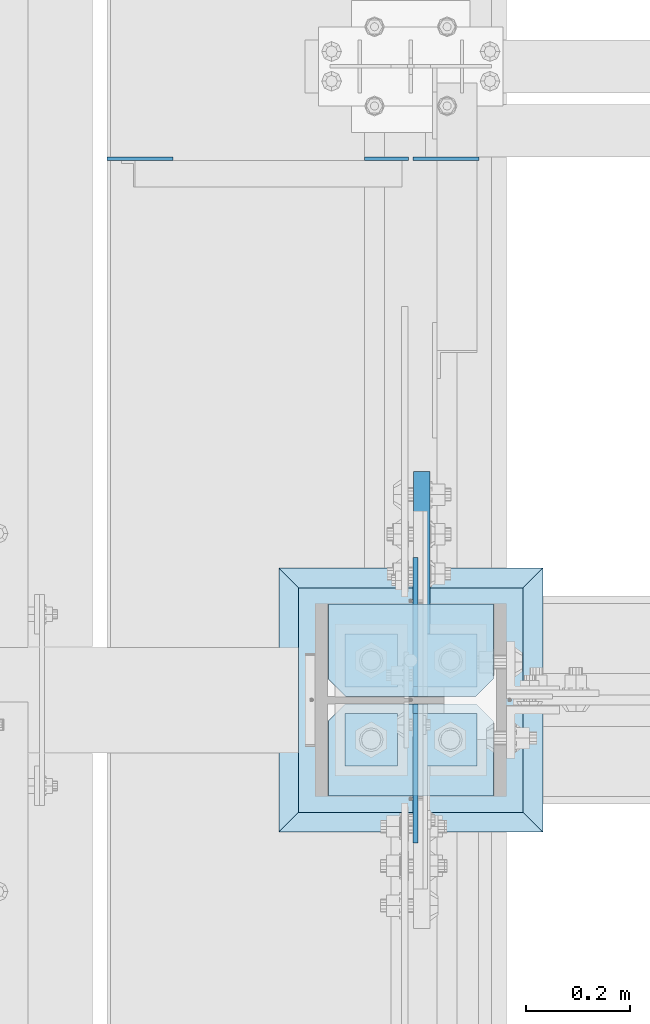
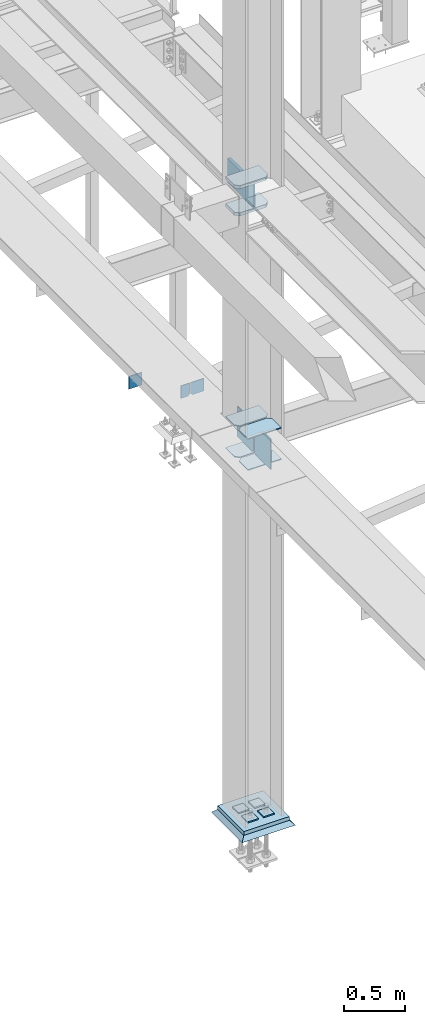
# One storey, part 3391 of 3843: 18 plates, 4 elements without a shape of their own.
"""IFC2X3 building model written with IfcOpenShell, lengths in millimetres."""

from ifc_helpers import new_model, si_unit, frame, origin_with_axes, place, context, subcontext, project, spatial, faceted_brep, material, type_object, element, aggregate, save


model = new_model("IFC2X3")

# Units and contexts
model_context = context("Model", 3, precision=1e-05, world=origin_with_axes())
body_context = subcontext(model_context, "Body", "Model", "MODEL_VIEW")
ifc_project = project(units=[si_unit("LENGTHUNIT", "METRE", prefix="MILLI"), si_unit("AREAUNIT", "SQUARE_METRE"), si_unit("VOLUMEUNIT", "CUBIC_METRE"), si_unit("MASSUNIT", "GRAM", prefix="KILO"), si_unit("TIMEUNIT", "SECOND"), si_unit("PLANEANGLEUNIT", "RADIAN"), si_unit("SOLIDANGLEUNIT", "STERADIAN"), si_unit("THERMODYNAMICTEMPERATUREUNIT", "DEGREE_CELSIUS"), si_unit("LUMINOUSINTENSITYUNIT", "LUMEN")], contexts=[model_context])

# Site, building, storey
site_placement = place(None, origin_with_axes())
site = spatial("IfcSite", under=ifc_project, at=site_placement, CompositionType="ELEMENT")
building_placement = place(site_placement, origin_with_axes())
building = spatial("IfcBuilding", under=site, at=building_placement, Name="Undefined", CompositionType="ELEMENT")
storey_placement = place(building_placement, origin_with_axes())
storey = spatial("IfcBuildingStorey", under=building, at=storey_placement, Name="Undefined", CompositionType="ELEMENT", Elevation=0.0)

# Assembly, plates
assembly_1_placement = place(storey_placement, origin_with_axes())
assembly_1 = element("IfcElementAssembly", 1, at=assembly_1_placement, inside=storey, Name="BEAM", AssemblyPlace="NOTDEFINED", PredefinedType="RIGID_FRAME")
ifc_material_1 = material(Name="STEEL/A572-50")
plate_type_1 = type_object("IfcPlateType", PredefinedType="NOTDEFINED")
plate_1_placement = place(assembly_1_placement, frame((36579.96875, 85026.5, 33769.3), z_axis=(0.0, 0.0, -1.0), x_axis=(1.0, 0.0, 0.0)))
plate_1 = element("IfcPlate", 2, at=plate_1_placement, type_object=plate_type_1, material=ifc_material_1, Name="PLATE", context=body_context, shape_type="Brep", body=[
    faceted_brep([(0.0, -3.17499999999927, 0.0), (0.0, -3.17500000000291, 107.950000000004), (0.0, 3.17500000000291, 107.950000000004), (0.0, 3.17499999999927, 0.0), (19.0500000000029, -3.17500000000291, 127.0), (19.0500000000029, 3.17500000000291, 127.0), (127.0, -3.17500000000291, 127.0), (127.0, 3.17500000000291, 127.0), (127.0, -3.17500000000291, 0.0), (127.0, 3.17500000000291, 0.0)], [[[0, 1, 2, 3]], [[1, 4, 5, 2]], [[4, 6, 7, 5]], [[6, 8, 9, 7]], [[8, 0, 3, 9]], [[5, 7, 9, 3, 2]], [[8, 6, 4, 1, 0]]]),
])
plate_2_placement = place(assembly_1_placement, frame((35991.8000305176, 85026.5000000001, 33909.0000061035), z_axis=(0.0, 0.0, 1.0), x_axis=(1.0, 0.0, 0.0)))
plate_2 = element("IfcPlate", 3, at=plate_2_placement, type_object=plate_type_1, material=ifc_material_1, Name="PLATE", context=body_context, shape_type="Brep", body=[
    faceted_brep([(0.0, -3.17499999999927, 0.0), (-6.10351708019152e-06, -3.17500000000291, 126.999993896483), (-6.10351708019152e-06, 3.17500000000291, 126.999993896483), (0.0, 3.17499999999927, 0.0), (127.0, -3.17500000000291, 127.0), (127.0, 3.17500000000291, 127.0), (127.0, -3.17500000000291, 0.0), (127.0, 3.17500000000291, 0.0)], [[[0, 1, 2, 3]], [[1, 4, 5, 2]], [[4, 6, 7, 5]], [[6, 0, 3, 7]], [[5, 7, 3, 2]], [[6, 4, 1, 0]]]),
])
plate_type_2 = type_object("IfcPlateType", PredefinedType="NOTDEFINED")
plate_3_placement = place(assembly_1_placement, frame((36572.0312591215, 85026.5, 33769.3), z_axis=(0.0, 0.0, -1.0), x_axis=(-1.0, 0.0, 0.0)))
plate_3 = element("IfcPlate", 4, at=plate_3_placement, type_object=plate_type_2, material=ifc_material_1, Name="PLATE", context=body_context, shape_type="Brep", body=[
    faceted_brep([(0.0, -3.17499999999927, 0.0), (0.0, -3.17500000000291, 107.950000000004), (0.0, 3.17500000000291, 107.950000000004), (0.0, 3.17499999999927, 0.0), (19.0500000000029, -3.17500000000291, 127.0), (19.0500000000029, 3.17500000000291, 127.0), (84.9312591264534, -3.17500000000291, 126.999993896701), (84.9312591264534, 3.17500000000291, 126.999993896701), (84.9312500000015, -3.17500000000291, 2.18278728425503e-10), (84.9312500000015, 3.17500000000291, 2.18278728425503e-10)], [[[0, 1, 2, 3]], [[1, 4, 5, 2]], [[4, 6, 7, 5]], [[6, 8, 9, 7]], [[8, 0, 3, 9]], [[5, 7, 9, 3, 2]], [[8, 6, 4, 1, 0]]]),
])
aggregate(assembly_1, [plate_1, plate_3, plate_2])

assembly_2_placement = place(storey_placement, origin_with_axes())
assembly_2 = element("IfcElementAssembly", 5, at=assembly_2_placement, inside=storey, Name="COLUMN", AssemblyPlace="NOTDEFINED", PredefinedType="RIGID_FRAME")
plate_type_3 = type_object("IfcPlateType", PredefinedType="NOTDEFINED")
plate_4_placement = place(assembly_2_placement, frame((36417.25, 83800.15625, 33688.3375), z_axis=(1.0, 0.0, 0.0), x_axis=(0.0, 1.0, 0.0)))
plate_4 = element("IfcPlate", 6, at=plate_4_placement, type_object=plate_type_3, material=ifc_material_1, Name="PLATE", context=body_context, shape_type="Brep", body=[
    faceted_brep([(0.0, -4.76249999999709, 0.0), (0.0, -4.76249999785796, 317.500000005042), (0.0, 4.76250000210712, 317.50000000505), (0.0, 4.76249999999709, 0.0), (144.462501525879, -4.76249999999709, 317.5), (144.462501525879, 4.76249999999709, 317.5), (177.800003051758, -4.76249999999709, 284.162498474121), (177.800003051758, 4.76249999999709, 284.162498474121), (177.800003051758, -4.76249999999709, 33.3375015258789), (177.800003051758, 4.76249999999709, 33.3375015258789), (144.462501525879, -4.76249999999709, 0.0), (144.462501525879, 4.76249999999709, 0.0)], [[[0, 1, 2, 3]], [[1, 4, 5, 2]], [[4, 6, 7, 5]], [[6, 8, 9, 7]], [[8, 10, 11, 9]], [[10, 0, 3, 11]], [[5, 7, 9, 11, 3, 2]], [[10, 8, 6, 4, 1, 0]]]),
])
plate_5_placement = place(assembly_2_placement, frame((36417.25, 83800.15625, 34002.6625), z_axis=(1.0, 0.0, 0.0), x_axis=(0.0, 1.0, 0.0)))
plate_5 = element("IfcPlate", 7, at=plate_5_placement, type_object=plate_type_3, material=ifc_material_1, Name="PLATE", context=body_context, shape_type="Brep", body=[
    faceted_brep([(0.0, -4.76249999999709, 0.0), (0.0, -4.76249999785796, 317.500000005042), (0.0, 4.76250000210712, 317.50000000505), (0.0, 4.76249999999709, 0.0), (144.462501525879, -4.76249999999709, 317.5), (144.462501525879, 4.76249999999709, 317.5), (177.800003051758, -4.76249999999709, 284.162498474121), (177.800003051758, 4.76249999999709, 284.162498474121), (177.800003051758, -4.76249999999709, 33.3375015258789), (177.800003051758, 4.76249999999709, 33.3375015258789), (144.462501525879, -4.76249999999709, 0.0), (144.462501525879, 4.76249999999709, 0.0)], [[[0, 1, 2, 3]], [[1, 4, 5, 2]], [[4, 6, 7, 5]], [[6, 8, 9, 7]], [[8, 10, 11, 9]], [[10, 0, 3, 11]], [[5, 7, 9, 11, 3, 2]], [[10, 8, 6, 4, 1, 0]]]),
])
plate_6_placement = place(assembly_2_placement, frame((36734.75, 84170.04375, 33688.3375), z_axis=(-1.0, 0.0, 0.0), x_axis=(0.0, -1.0, 0.0)))
plate_6 = element("IfcPlate", 8, at=plate_6_placement, type_object=plate_type_3, material=ifc_material_1, Name="PLATE", context=body_context, shape_type="Brep", body=[
    faceted_brep([(0.0, -4.76249999999709, 0.0), (0.0, -4.76249999785796, 317.500000005042), (0.0, 4.76250000210712, 317.50000000505), (0.0, 4.76249999999709, 0.0), (144.462501525879, -4.76249999999709, 317.5), (144.462501525879, 4.76249999999709, 317.5), (177.800003051758, -4.76249999999709, 284.162498474121), (177.800003051758, 4.76249999999709, 284.162498474121), (177.800003051758, -4.76249999999709, 33.3375015258789), (177.800003051758, 4.76249999999709, 33.3375015258789), (144.462501525879, -4.76249999999709, 0.0), (144.462501525879, 4.76249999999709, 0.0)], [[[0, 1, 2, 3]], [[1, 4, 5, 2]], [[4, 6, 7, 5]], [[6, 8, 9, 7]], [[8, 10, 11, 9]], [[10, 0, 3, 11]], [[5, 7, 9, 11, 3, 2]], [[10, 8, 6, 4, 1, 0]]]),
])
plate_7_placement = place(assembly_2_placement, frame((36734.75, 84170.04375, 34002.6625), z_axis=(-1.0, 0.0, 0.0), x_axis=(0.0, -1.0, 0.0)))
plate_7 = element("IfcPlate", 9, at=plate_7_placement, type_object=plate_type_3, material=ifc_material_1, Name="PLATE", context=body_context, shape_type="Brep", body=[
    faceted_brep([(0.0, -4.76249999999709, 0.0), (0.0, -4.76249999785796, 317.500000005042), (0.0, 4.76250000210712, 317.50000000505), (0.0, 4.76249999999709, 0.0), (144.462501525879, -4.76249999999709, 317.5), (144.462501525879, 4.76249999999709, 317.5), (177.800003051758, -4.76249999999709, 284.162498474121), (177.800003051758, 4.76249999999709, 284.162498474121), (177.800003051758, -4.76249999999709, 33.3375015258789), (177.800003051758, 4.76249999999709, 33.3375015258789), (144.462501525879, -4.76249999999709, 0.0), (144.462501525879, 4.76249999999709, 0.0)], [[[0, 1, 2, 3]], [[1, 4, 5, 2]], [[4, 6, 7, 5]], [[6, 8, 9, 7]], [[8, 10, 11, 9]], [[10, 0, 3, 11]], [[5, 7, 9, 11, 3, 2]], [[10, 8, 6, 4, 1, 0]]]),
])
plate_type_4 = type_object("IfcPlateType", PredefinedType="NOTDEFINED")
plate_8_placement = place(assembly_2_placement, frame((36734.75, 84170.04375, 36128.325), z_axis=(-1.0, 0.0, 0.0), x_axis=(0.0, -1.0, 0.0)))
plate_8 = element("IfcPlate", 10, at=plate_8_placement, type_object=plate_type_4, material=ifc_material_1, Name="PLATE", context=body_context, shape_type="Brep", body=[
    faceted_brep([(0.0, -15.875, 0.0), (0.0, -15.875, 317.5), (0.0, 15.875, 317.5), (0.0, 15.875, 0.0), (144.462498511086, -15.874999999156, 317.499999999665), (144.462498511086, 15.875000000844, 317.499999999578), (177.800000033079, -15.8749999992506, 284.162498473786), (177.800000033079, 15.8750000007494, 284.162498473699), (177.800000003888, -15.8749999999054, 33.3375015259226), (177.800000003888, 15.8750000000946, 33.3375015258353), (144.462498474124, -15.875, 0.0), (144.462498474124, 15.875, 0.0)], [[[0, 1, 2, 3]], [[1, 4, 5, 2]], [[4, 6, 7, 5]], [[6, 8, 9, 7]], [[8, 10, 11, 9]], [[10, 0, 3, 11]], [[5, 7, 9, 11, 3, 2]], [[10, 8, 6, 4, 1, 0]]]),
])
plate_9_placement = place(assembly_2_placement, frame((36734.75, 84170.04375, 36401.375), z_axis=(-1.0, 0.0, 0.0), x_axis=(0.0, -1.0, 0.0)))
plate_9 = element("IfcPlate", 11, at=plate_9_placement, type_object=plate_type_4, material=ifc_material_1, Name="PLATE", context=body_context, shape_type="Brep", body=[
    faceted_brep([(0.0, -15.875, 0.0), (0.0, -15.875, 317.5), (0.0, 15.875, 317.5), (0.0, 15.875, 0.0), (144.462498511086, -15.874999999156, 317.499999999665), (144.462498511086, 15.875000000844, 317.499999999578), (177.800000033079, -15.8749999992506, 284.162498473786), (177.800000033079, 15.8750000007494, 284.162498473699), (177.800000003888, -15.8749999999054, 33.3375015259226), (177.800000003888, 15.8750000000946, 33.3375015258353), (144.462498474124, -15.875, 0.0), (144.462498474124, 15.875, 0.0)], [[[0, 1, 2, 3]], [[1, 4, 5, 2]], [[4, 6, 7, 5]], [[6, 8, 9, 7]], [[8, 10, 11, 9]], [[10, 0, 3, 11]], [[5, 7, 9, 11, 3, 2]], [[10, 8, 6, 4, 1, 0]]]),
])

assembly_3_placement = place(storey_placement, origin_with_axes())
assembly_3 = element("IfcElementAssembly", 12, at=assembly_3_placement, inside=storey, Name="TEMPLATE", AssemblyPlace="NOTDEFINED", PredefinedType="RIGID_FRAME")
plate_type_5 = type_object("IfcPlateType", PredefinedType="NOTDEFINED")
plate_10_placement = place(assembly_3_placement, frame((36601.4, 83959.7, 30105.35), z_axis=(0.0, -1.0, 0.0), x_axis=(1.0, 0.0, 0.0)))
plate_10 = element("IfcPlate", 13, at=plate_10_placement, type_object=plate_type_5, material=ifc_material_1, Name="Washer Plate", context=body_context, shape_type="Brep", body=[
    faceted_brep([(0.0, -6.3499999046162, 0.0), (-1.67347025126219e-10, -6.35000000000582, 101.600000000151), (-1.67347025126219e-10, 6.35000000000582, 101.600000000151), (7.27595761418343e-12, 6.3499999046162, 0.0), (101.599998474121, -6.34999999999854, 101.599998474121), (101.599998474121, 6.34999999999854, 101.599998474121), (101.6, -6.34999999999854, 0.0), (101.6, 6.34999999999854, 0.0)], [[[0, 1, 2, 3]], [[1, 4, 5, 2]], [[4, 6, 7, 5]], [[6, 0, 3, 7]], [[5, 7, 3, 2]], [[6, 4, 1, 0]]]),
])
plate_11_placement = place(assembly_3_placement, frame((36601.4, 84112.1, 30105.35), z_axis=(0.0, -1.0, 0.0), x_axis=(1.0, 0.0, 0.0)))
plate_11 = element("IfcPlate", 14, at=plate_11_placement, type_object=plate_type_5, material=ifc_material_1, Name="Washer Plate", context=body_context, shape_type="Brep", body=[
    faceted_brep([(0.0, -6.3499999046162, 0.0), (-1.67347025126219e-10, -6.35000000000582, 101.600000000151), (-1.67347025126219e-10, 6.35000000000582, 101.600000000151), (7.27595761418343e-12, 6.3499999046162, 0.0), (101.599998474121, -6.34999999999854, 101.599998474121), (101.599998474121, 6.34999999999854, 101.599998474121), (101.6, -6.34999999999854, 0.0), (101.6, 6.34999999999854, 0.0)], [[[0, 1, 2, 3]], [[1, 4, 5, 2]], [[4, 6, 7, 5]], [[6, 0, 3, 7]], [[5, 7, 3, 2]], [[6, 4, 1, 0]]]),
])
plate_12_placement = place(assembly_3_placement, frame((36449.0, 83959.7, 30105.35), z_axis=(0.0, -1.0, 0.0), x_axis=(1.0, 0.0, 0.0)))
plate_12 = element("IfcPlate", 15, at=plate_12_placement, type_object=plate_type_5, material=ifc_material_1, Name="Washer Plate", context=body_context, shape_type="Brep", body=[
    faceted_brep([(0.0, -6.3499999046162, 0.0), (-1.67347025126219e-10, -6.35000000000582, 101.600000000151), (-1.67347025126219e-10, 6.35000000000582, 101.600000000151), (7.27595761418343e-12, 6.3499999046162, 0.0), (101.599998474121, -6.34999999999854, 101.599998474121), (101.599998474121, 6.34999999999854, 101.599998474121), (101.6, -6.34999999999854, 0.0), (101.6, 6.34999999999854, 0.0)], [[[0, 1, 2, 3]], [[1, 4, 5, 2]], [[4, 6, 7, 5]], [[6, 0, 3, 7]], [[5, 7, 3, 2]], [[6, 4, 1, 0]]]),
])
plate_13_placement = place(assembly_3_placement, frame((36449.0, 84112.1, 30105.35), z_axis=(0.0, -1.0, 0.0), x_axis=(1.0, 0.0, 0.0)))
plate_13 = element("IfcPlate", 16, at=plate_13_placement, type_object=plate_type_5, material=ifc_material_1, Name="Washer Plate", context=body_context, shape_type="Brep", body=[
    faceted_brep([(0.0, -6.3499999046162, 0.0), (-1.67347025126219e-10, -6.35000000000582, 101.600000000151), (-1.67347025126219e-10, 6.35000000000582, 101.600000000151), (7.27595761418343e-12, 6.3499999046162, 0.0), (101.599998474121, -6.34999999999854, 101.599998474121), (101.599998474121, 6.34999999999854, 101.599998474121), (101.6, -6.34999999999854, 0.0), (101.6, 6.34999999999854, 0.0)], [[[0, 1, 2, 3]], [[1, 4, 5, 2]], [[4, 6, 7, 5]], [[6, 0, 3, 7]], [[5, 7, 3, 2]], [[6, 4, 1, 0]]]),
])
aggregate(assembly_3, [plate_10, plate_11, plate_12, plate_13])

# Plate
plate_type_6 = type_object("IfcPlateType", PredefinedType="NOTDEFINED")
plate_14_placement = place(assembly_2_placement, frame((36584.73125, 83977.95625, 33712.1500026613), z_axis=(0.0, -0.707106781186682, 0.707106781186413), x_axis=(0.0, -0.707106781186548, -0.707106781186548)))
plate_14 = element("IfcPlate", 17, at=plate_14_placement, type_object=plate_type_6, material=ifc_material_1, Name="PLATE", context=body_context, shape_type="Brep", body=[
    faceted_brep([(0.0, -4.76249999999709, 0.0), (-188.585379946875, -4.76249999999709, 188.585377136231), (-188.585379946875, 4.76249999999709, 188.585377136231), (0.0, 4.76249999999709, 0.0), (-188.585379946759, -4.76249999999709, 215.526145298725), (-188.585379946759, 4.76249999999709, 215.526145298725), (-12.9091160607786, -4.76250000000073, 391.202408440829), (-12.9091160607786, 4.76250000000073, 391.202408440829), (202.617028732588, -4.76249999999709, 175.676260369546), (202.617028732588, 4.76249999999709, 175.676260369546), (26.9407683631998, -4.76249999999709, 1.30967237055302e-10), (26.9407683631998, 4.76249999999709, 1.30967237055302e-10)], [[[0, 1, 2, 3]], [[1, 4, 5, 2]], [[4, 6, 7, 5]], [[6, 8, 9, 7]], [[8, 10, 11, 9]], [[10, 0, 3, 11]], [[5, 7, 9, 11, 3, 2]], [[10, 8, 6, 4, 1, 0]]]),
])

plate_15_placement = place(assembly_2_placement, frame((36584.73125, 83992.24375, 33712.1500026613), z_axis=(0.0, 0.707106781186548, 0.707106781186548), x_axis=(5.70000238222118e-08, 0.707106781186546, -0.707106781186546)))
plate_15 = element("IfcPlate", 18, at=plate_15_placement, type_object=plate_type_6, material=ifc_material_1, Name="PLATE", context=body_context, shape_type="Brep", body=[
    faceted_brep([(0.0, -4.76249999999709, 0.0), (-188.585379946875, -4.76249999999709, 188.585377136231), (-188.585379946875, 4.76249999999709, 188.585377136231), (0.0, 4.76249999999709, 0.0), (-188.585379946759, -4.76249999999709, 215.526145298725), (-188.585379946759, 4.76249999999709, 215.526145298725), (-12.9091160607786, -4.76250000000073, 391.202408440829), (-12.9091160607786, 4.76250000000073, 391.202408440829), (202.617028732588, -4.76249999999709, 175.676260369546), (202.617028732588, 4.76249999999709, 175.676260369546), (26.9407683631998, -4.76249999999709, 1.30967237055302e-10), (26.9407683631998, 4.76249999999709, 1.30967237055302e-10)], [[[0, 1, 2, 3]], [[1, 4, 5, 2]], [[4, 6, 7, 5]], [[6, 8, 9, 7]], [[8, 10, 11, 9]], [[10, 0, 3, 11]], [[5, 7, 9, 11, 3, 2]], [[10, 8, 6, 4, 1, 0]]]),
])

plate_type_7 = type_object("IfcPlateType", PredefinedType="NOTDEFINED")
plate_16_placement = place(assembly_2_placement, frame((36597.43125, 83992.24375, 36385.5), z_axis=(0.0, 1.0, 0.0), x_axis=(0.0, 0.0, -1.0)))
plate_16 = element("IfcPlate", 19, at=plate_16_placement, type_object=plate_type_7, material=ifc_material_1, Name="PLATE", context=body_context, shape_type="Brep", body=[
    faceted_brep([(241.300003051758, -15.875, 28.5749999999971), (0.0, -15.875, 28.5750007629395), (0.0, -6.34999999999854, 19.0499992370605), (19.0500015258731, 12.6999999999971, 0.0), (222.250003814697, 12.6999999999971, 0.0), (241.300003051758, -6.34999923706346, 19.0499992370605), (0.0, -15.875, 432.59375), (0.0, 15.875, 432.59375), (0.0, 15.875, 19.0499992370605), (241.300003051758, -15.875, 432.59375), (241.300003051758, 15.875, 432.59375), (241.300003051758, 15.875, 19.0499992370605), (222.250003814697, 15.875, 0.0), (19.0500015258804, 15.875, 0.0)], [[[0, 1, 2, 3, 4, 5]], [[6, 7, 8, 2, 1]], [[6, 9, 10, 7]], [[11, 10, 9, 0, 5]], [[12, 11, 5, 4]], [[13, 12, 4, 3]], [[8, 13, 3, 2]], [[10, 11, 12, 13, 8, 7]], [[9, 6, 1, 0]]]),
])

plate_type_8 = type_object("IfcPlateType", PredefinedType="NOTDEFINED")
plate_17_placement = place(assembly_2_placement, frame((36360.1, 83769.2, 30079.95), z_axis=(0.0, 1.0, 0.0), x_axis=(1.0, 0.0, 0.0)))
plate_17 = element("IfcPlate", 20, at=plate_17_placement, type_object=plate_type_8, material=ifc_material_1, Name="PLATE", context=body_context, shape_type="Brep", body=[
    faceted_brep([(0.0, -19.0500000000029, 0.0), (0.0, -19.0499999999993, 431.799987792969), (0.0, 19.0499999999993, 431.799987792969), (0.0, 19.0500000000029, 0.0), (431.799987792969, -19.0499999999993, 431.799987792969), (431.799987792969, 19.0499999999993, 431.799987792969), (431.799957275391, -19.0499999999993, 0.0), (431.799957275391, 19.0499999999993, 0.0)], [[[0, 1, 2, 3]], [[1, 4, 5, 2]], [[4, 6, 7, 5]], [[6, 0, 3, 7]], [[5, 7, 3, 2]], [[6, 4, 1, 0]]]),
])

aggregate(assembly_2, [plate_16, plate_8, plate_9, plate_4, plate_5, plate_14, plate_6, plate_7, plate_15, plate_17])

# Assembly, plate
assembly_4_placement = place(storey_placement, origin_with_axes())
assembly_4 = element("IfcElementAssembly", 21, at=assembly_4_placement, inside=storey, Name="GROUT", AssemblyPlace="NOTDEFINED", PredefinedType="REINFORCEMENT_UNIT")
ifc_material_2 = material(Name="CONCRETE/Concrete_Undefined")
plate_type_9 = type_object("IfcPlateType", PredefinedType="NOTDEFINED")
plate_18_placement = place(assembly_4_placement, frame((36322.0, 83731.1, 30041.85), z_axis=(0.0, 1.0, 0.0), x_axis=(1.0, 0.0, 0.0)))
plate_18 = element("IfcPlate", 22, at=plate_18_placement, type_object=plate_type_9, material=ifc_material_2, Name="GROUT", context=body_context, shape_type="Brep", body=[
    faceted_brep([(38.1000000007043, -19.0499999997883, 469.899999999314), (0.0, 19.0499999999993, 508.0), (0.0, 19.0500000000029, 0.0), (38.1000000006916, -19.0499999999811, 38.1000000006607), (469.899999999325, -19.0499999998174, 38.1000000006607), (508.0, 19.0499999999993, 0.0), (508.0, 19.0499999999993, 508.0), (469.899999999325, -19.0499999999847, 469.899999999314)], [[[0, 1, 2, 3]], [[4, 5, 6, 7]], [[4, 7, 0, 3]], [[5, 4, 3, 2]], [[6, 5, 2, 1]], [[7, 6, 1, 0]]]),
])
aggregate(assembly_4, [plate_18])

save(model, "model.ifc")
